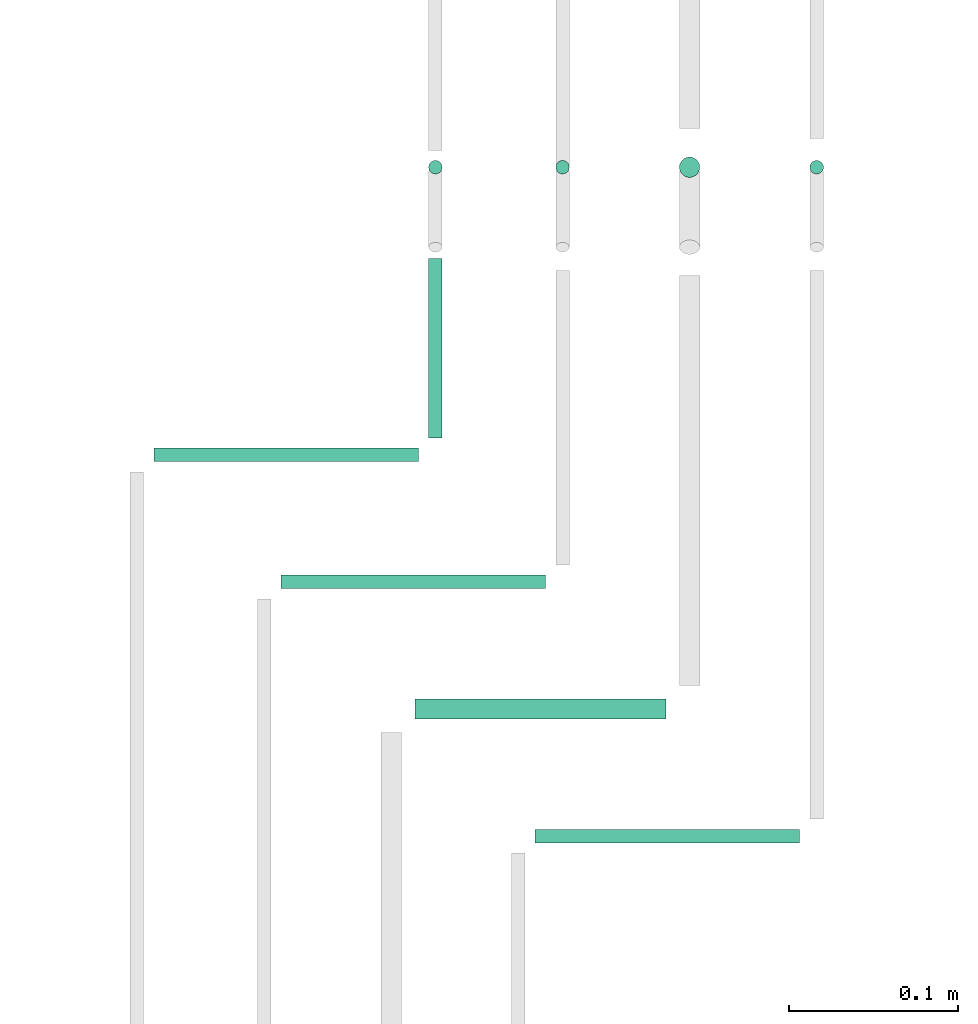
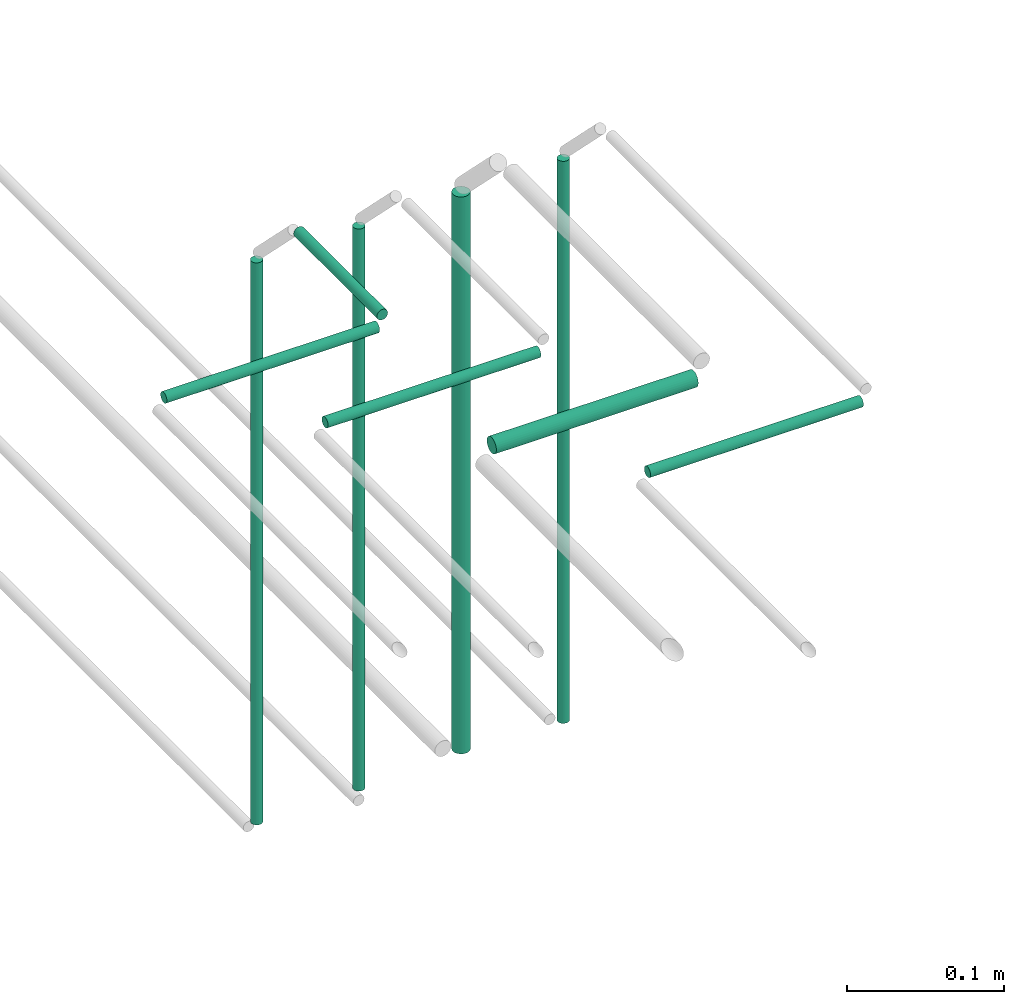
# One storey, part 165 of 331: 9 flow segments.
"""IFC2X3 building model written with IfcOpenShell, lengths in millimetres."""

from ifc_helpers import new_model, entity, si_unit, converted_unit, derived_unit, direction, frame, frame_2d, origin, origin_2d_with_axis, place, context, subcontext, project, spatial, circle, extrude, type_object, element, save


model = new_model("IFC2X3")

# Units and contexts
model_context = context("Model", 3, precision=0.01, world=origin(), true_north=direction((6.12303176911189e-17, 1.0)))
body_context = subcontext(model_context, "Body", "Model", "MODEL_VIEW")
ifc_project = project(units=[si_unit("LENGTHUNIT", "METRE", prefix="MILLI"), si_unit("AREAUNIT", "SQUARE_METRE"), si_unit("VOLUMEUNIT", "CUBIC_METRE"), converted_unit("PLANEANGLEUNIT", "DEGREE", entity("IfcRatioMeasure", 0.0174532925199433), si_unit("PLANEANGLEUNIT", "RADIAN"), dimensions=[0, 0, 0, 0, 0, 0, 0]), si_unit("MASSUNIT", "GRAM", prefix="KILO"), derived_unit("MASSDENSITYUNIT", [(si_unit("MASSUNIT", "GRAM", prefix="KILO"), 1), (si_unit("LENGTHUNIT", "METRE"), -3)]), derived_unit("MOMENTOFINERTIAUNIT", [(si_unit("LENGTHUNIT", "METRE"), 4)]), si_unit("TIMEUNIT", "SECOND"), si_unit("FREQUENCYUNIT", "HERTZ"), si_unit("THERMODYNAMICTEMPERATUREUNIT", "DEGREE_CELSIUS"), derived_unit("THERMALTRANSMITTANCEUNIT", [(si_unit("MASSUNIT", "GRAM", prefix="KILO"), 1), (si_unit("THERMODYNAMICTEMPERATUREUNIT", "KELVIN"), -1), (si_unit("TIMEUNIT", "SECOND"), -3)]), derived_unit("VOLUMETRICFLOWRATEUNIT", [(si_unit("LENGTHUNIT", "METRE"), 3), (si_unit("TIMEUNIT", "SECOND"), -1)]), derived_unit("MASSFLOWRATEUNIT", [(si_unit("MASSUNIT", "GRAM", prefix="KILO"), 1), (si_unit("TIMEUNIT", "SECOND"), -1)]), derived_unit("ROTATIONALFREQUENCYUNIT", [(si_unit("TIMEUNIT", "SECOND"), -1)]), si_unit("ELECTRICCURRENTUNIT", "AMPERE"), si_unit("ELECTRICVOLTAGEUNIT", "VOLT"), si_unit("POWERUNIT", "WATT"), si_unit("FORCEUNIT", "NEWTON", prefix="KILO"), si_unit("ILLUMINANCEUNIT", "LUX"), si_unit("LUMINOUSFLUXUNIT", "LUMEN"), si_unit("LUMINOUSINTENSITYUNIT", "CANDELA"), derived_unit("USERDEFINED", [(si_unit("MASSUNIT", "GRAM", prefix="KILO"), -1), (si_unit("LENGTHUNIT", "METRE"), -2), (si_unit("TIMEUNIT", "SECOND"), 3), (si_unit("LUMINOUSFLUXUNIT", "LUMEN"), 1)]), derived_unit("LINEARVELOCITYUNIT", [(si_unit("LENGTHUNIT", "METRE"), 1), (si_unit("TIMEUNIT", "SECOND"), -1)]), si_unit("PRESSUREUNIT", "PASCAL"), derived_unit("USERDEFINED", [(si_unit("LENGTHUNIT", "METRE"), -2), (si_unit("MASSUNIT", "GRAM", prefix="KILO"), 1), (si_unit("TIMEUNIT", "SECOND"), -2)]), derived_unit("LINEARFORCEUNIT", [(si_unit("MASSUNIT", "GRAM", prefix="KILO"), 1), (si_unit("LENGTHUNIT", "METRE"), 1), (si_unit("TIMEUNIT", "SECOND"), -2), (si_unit("LENGTHUNIT", "METRE"), -1)]), derived_unit("PLANARFORCEUNIT", [(si_unit("MASSUNIT", "GRAM", prefix="KILO"), 1), (si_unit("LENGTHUNIT", "METRE"), 1), (si_unit("TIMEUNIT", "SECOND"), -2), (si_unit("LENGTHUNIT", "METRE"), -2)])], contexts=[model_context])

# Site, building, storey
site_placement = place(None, frame((0.0, -0.00077364408347762, 0.0)))
site = spatial("IfcSite", under=ifc_project, at=site_placement, CompositionType="ELEMENT")
building_placement = place(site_placement, origin())
building = spatial("IfcBuilding", under=site, at=building_placement, CompositionType="ELEMENT")
storey_placement = place(building_placement, origin())
storey = spatial("IfcBuildingStorey", under=building, at=storey_placement, CompositionType="ELEMENT", Elevation=0.0)

# Flow segments
pipe_segment_type = type_object("IfcPipeSegmentType", PredefinedType="NOTDEFINED")
flow_segment_1_placement = place(building_placement, frame((40316.4101011924, 14004.405560894, 6760.0)))
element("IfcFlowSegment", 1, at=flow_segment_1_placement, inside=storey, type_object=pipe_segment_type, context=body_context, shape_type="SweptSolid", body=[
    extrude(circle(Radius=4.0, at=origin_2d_with_axis()), frame((5.59527223591499, 5.59527223591499, 0.0), z_axis=(0.0, 0.0, 1.0), x_axis=(-1.0, 0.0, 0.0)), (0.0, 0.0, 1.0), 436.000000000013),
])
flow_segment_2_placement = place(building_placement, frame((40316.4101011924, 13850.2360411716, 7244.40472776408)))
element("IfcFlowSegment", 2, at=flow_segment_2_placement, inside=storey, type_object=pipe_segment_type, context=body_context, shape_type="SweptSolid", body=[
    extrude(circle(Radius=4.0, at=origin_2d_with_axis()), frame((5.59527223591499, 0.0, 5.59527223591607), z_axis=(0.0, 1.0, 0.0), x_axis=(1.0, 0.0, 0.0)), (0.0, 0.0, 1.0), 105.764791958309),
])
flow_segment_3_placement = place(storey_placement, frame((40391.4101011924, 14004.405560894, 6760.0)))
element("IfcFlowSegment", 3, at=flow_segment_3_placement, inside=storey, type_object=pipe_segment_type, context=body_context, shape_type="SweptSolid", body=[
    extrude(circle(Radius=4.0, at=origin_2d_with_axis()), frame((5.59527223591499, 5.59527223591499, 0.0), z_axis=(0.0, 0.0, 1.0), x_axis=(-1.0, 0.0, 0.0)), (0.0, 0.0, 1.0), 436.000000000013),
])
flow_segment_4_placement = place(storey_placement, frame((40464.4101011924, 14002.405560894, 6764.0)))
element("IfcFlowSegment", 4, at=flow_segment_4_placement, inside=storey, type_object=pipe_segment_type, context=body_context, shape_type="SweptSolid", body=[
    extrude(circle(Radius=6.0, at=origin_2d_with_axis()), frame((7.59527223591454, 7.5952722359167, 0.0), z_axis=(0.0, 0.0, 1.0), x_axis=(-1.0, 0.0, 0.0)), (0.0, 0.0, 1.0), 432.000000000012),
])
flow_segment_5_placement = place(storey_placement, frame((40541.4101011924, 14004.405560894, 6760.0)))
element("IfcFlowSegment", 5, at=flow_segment_5_placement, inside=storey, type_object=pipe_segment_type, context=body_context, shape_type="SweptSolid", body=[
    extrude(circle(Radius=4.0, at=origin_2d_with_axis()), frame((5.59527223591499, 5.59527223591499, 0.0), z_axis=(0.0, 0.0, 1.0), x_axis=(-1.0, 0.0, 0.0)), (0.0, 0.0, 1.0), 436.000000000013),
])
flow_segment_6_placement = place(building_placement, frame((40155.8306299097, 13834.6407689357, 7244.40472776408)))
element("IfcFlowSegment", 6, at=flow_segment_6_placement, inside=storey, type_object=pipe_segment_type, context=body_context, shape_type="SweptSolid", body=[
    extrude(circle(Radius=4.0, at=frame_2d((-4.33146851719357e-12, -1.08286712929839e-12), x_axis=(1.0, 0.0))), frame((0.0, 5.59527223591932, 5.59527223591716), z_axis=(1.0, 0.0, 0.0), x_axis=(0.0, 1.0, 0.0)), (0.0, 0.0, 1.0), 156.174743518586),
])
flow_segment_7_placement = place(storey_placement, frame((40230.8306299097, 13759.6407689357, 7244.40472776409)))
element("IfcFlowSegment", 7, at=flow_segment_7_placement, inside=storey, type_object=pipe_segment_type, context=body_context, shape_type="SweptSolid", body=[
    extrude(circle(Radius=4.0, at=frame_2d((-1.51601398101775e-11, 0.0), x_axis=(1.0, 0.0))), frame((0.0, 5.59527223592799, 5.59527223591607), z_axis=(1.0, 0.0, 0.0), x_axis=(0.0, 1.0, 0.0)), (0.0, 0.0, 1.0), 156.174743518586),
])
flow_segment_8_placement = place(storey_placement, frame((40309.8306299097, 13682.6407689356, 7242.40472776407)))
element("IfcFlowSegment", 8, at=flow_segment_8_placement, inside=storey, type_object=pipe_segment_type, context=body_context, shape_type="SweptSolid", body=[
    extrude(circle(Radius=6.0, at=frame_2d((-2.16573425859679e-11, -1.08286712929839e-12), x_axis=(1.0, 0.0))), frame((0.0, 7.59527223593836, 7.5952722359167), z_axis=(1.0, 0.0, 0.0), x_axis=(0.0, 1.0, 0.0)), (0.0, 0.0, 1.0), 148.174743518588),
])
flow_segment_9_placement = place(storey_placement, frame((40380.8306299097, 13609.6407689356, 7244.40472776406)))
element("IfcFlowSegment", 9, at=flow_segment_9_placement, inside=storey, type_object=pipe_segment_type, context=body_context, shape_type="SweptSolid", body=[
    extrude(circle(Radius=4.0, at=frame_2d((-3.24860138789518e-11, -1.08286712929839e-12), x_axis=(1.0, 0.0))), frame((0.0, 5.59527223594748, 5.59527223591716), z_axis=(1.0, 0.0, 0.0), x_axis=(0.0, 1.0, 0.0)), (0.0, 0.0, 1.0), 156.174743518586),
])

save(model, "model.ifc")
